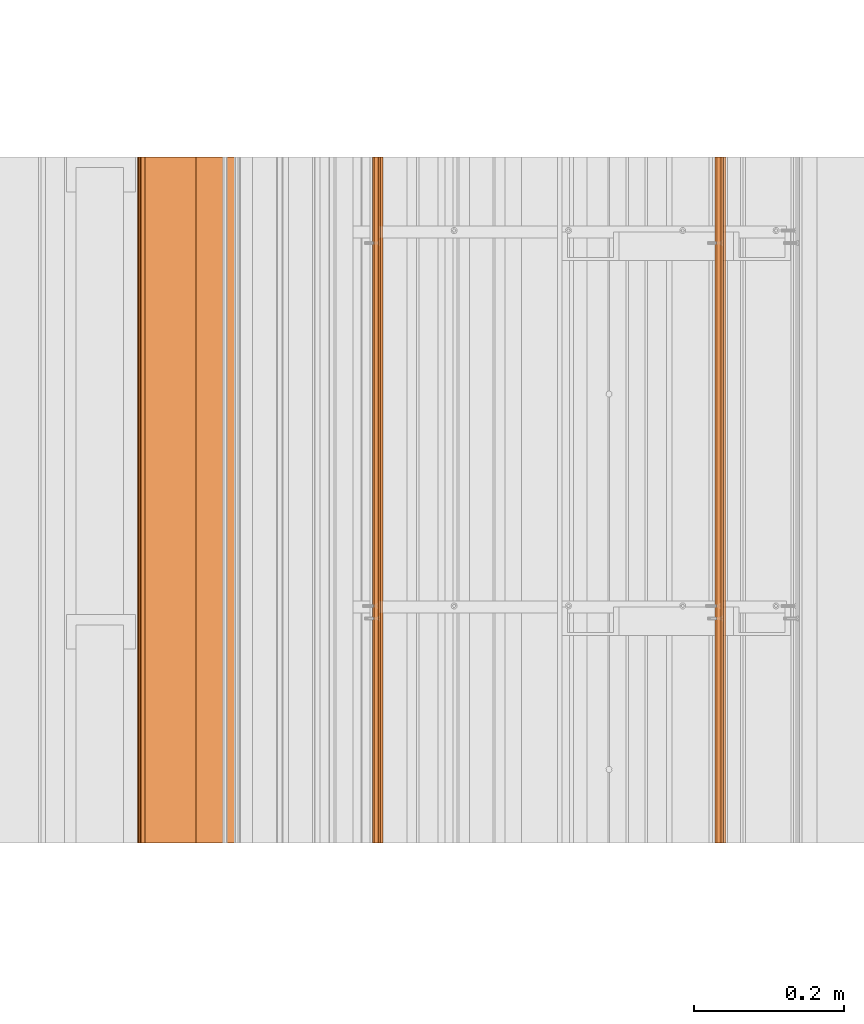
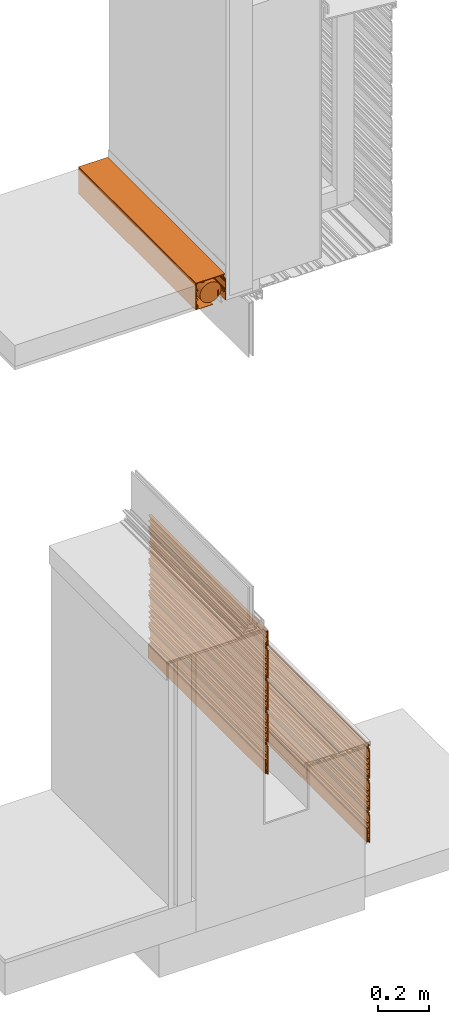
# One storey, part 4 of 36: 13 proxies.
"""IFC2X3 building model written with IfcOpenShell, lengths in feet."""

from ifc_helpers import new_model, entity, si_unit, converted_unit, derived_unit, direction, frame, frame_2d, origin, place, context, subcontext, project, spatial, polyline, circle_curve, parameter, trimmed, segment, composite_curve, outline, extrude, source, transform, mapped, material, type_object, type_shapes, element, save


model = new_model("IFC2X3")

# Units and contexts
model_context = context("Model", 3, precision=0.0001, world=origin(), true_north=direction((6.12303176911189e-17, 1.0)))
body_context = subcontext(model_context, "Body", "Model", "MODEL_VIEW")
ifc_project = project(units=[converted_unit("LENGTHUNIT", "FOOT", entity("IfcRatioMeasure", 0.3048), si_unit("LENGTHUNIT", "METRE"), dimensions=[1, 0, 0, 0, 0, 0, 0]), converted_unit("AREAUNIT", "SQUARE FOOT", entity("IfcRatioMeasure", 0.09290304), si_unit("AREAUNIT", "SQUARE_METRE"), dimensions=[2, 0, 0, 0, 0, 0, 0]), converted_unit("VOLUMEUNIT", "CUBIC FOOT", entity("IfcRatioMeasure", 0.028316846592), si_unit("VOLUMEUNIT", "CUBIC_METRE"), dimensions=[3, 0, 0, 0, 0, 0, 0]), converted_unit("PLANEANGLEUNIT", "DEGREE", entity("IfcRatioMeasure", 0.0174532925199433), si_unit("PLANEANGLEUNIT", "RADIAN"), dimensions=[0, 0, 0, 0, 0, 0, 0]), si_unit("MASSUNIT", "GRAM", prefix="KILO"), derived_unit("MASSDENSITYUNIT", [(si_unit("MASSUNIT", "GRAM", prefix="KILO"), 1), (si_unit("LENGTHUNIT", "METRE"), -3)]), si_unit("TIMEUNIT", "SECOND"), si_unit("FREQUENCYUNIT", "HERTZ"), si_unit("THERMODYNAMICTEMPERATUREUNIT", "DEGREE_CELSIUS"), derived_unit("THERMALTRANSMITTANCEUNIT", [(si_unit("MASSUNIT", "GRAM", prefix="KILO"), 1), (si_unit("THERMODYNAMICTEMPERATUREUNIT", "KELVIN"), -1), (si_unit("TIMEUNIT", "SECOND"), -3)]), derived_unit("VOLUMETRICFLOWRATEUNIT", [(si_unit("LENGTHUNIT", "METRE"), 3), (si_unit("TIMEUNIT", "SECOND"), -1)]), si_unit("ELECTRICCURRENTUNIT", "AMPERE"), si_unit("ELECTRICVOLTAGEUNIT", "VOLT"), si_unit("POWERUNIT", "WATT"), si_unit("FORCEUNIT", "NEWTON"), si_unit("ILLUMINANCEUNIT", "LUX"), si_unit("LUMINOUSFLUXUNIT", "LUMEN"), si_unit("LUMINOUSINTENSITYUNIT", "CANDELA"), derived_unit("USERDEFINED", [(si_unit("MASSUNIT", "GRAM", prefix="KILO"), -1), (si_unit("LENGTHUNIT", "METRE"), -2), (si_unit("TIMEUNIT", "SECOND"), 3), (si_unit("LUMINOUSFLUXUNIT", "LUMEN"), 1)]), derived_unit("LINEARVELOCITYUNIT", [(si_unit("LENGTHUNIT", "METRE"), 1), (si_unit("TIMEUNIT", "SECOND"), -1)]), si_unit("PRESSUREUNIT", "PASCAL"), derived_unit("USERDEFINED", [(si_unit("LENGTHUNIT", "METRE"), -2), (si_unit("MASSUNIT", "GRAM", prefix="KILO"), 1), (si_unit("TIMEUNIT", "SECOND"), -2)])], contexts=[model_context])

# Site, building, storey
site_placement = place(None, origin())
site = spatial("IfcSite", under=ifc_project, at=site_placement, CompositionType="ELEMENT")
building_placement = place(site_placement, origin())
building = spatial("IfcBuilding", under=site, at=building_placement, CompositionType="ELEMENT")
storey_placement = place(building_placement, origin())
storey = spatial("IfcBuildingStorey", under=building, at=storey_placement, Name="Level 1", CompositionType="ELEMENT", Elevation=0.0)

# Proxies
ifc_material_1 = material(Name="_EXISTING CAST-IN-PLACE CONCRETE")
building_element_proxy_type_1 = type_object("IfcBuildingElementProxyType", Name="panel 048", PredefinedType="NOTDEFINED", material=ifc_material_1)
shared_shape_1 = source(origin(), body_context, "Body", "SweptSolid", [
    extrude(outline(polyline([(-0.145680147068469, -0.0220175316851652), (0.291819852931525, -0.0220175316851652), (0.291819852931525, -0.011600865018508), (0.237132352931535, -0.011600865018508), (0.237132352931535, 0.00451787028335104), (0.257965686264864, 0.00451787028335104), (0.257965686264864, 0.0173047730392568), (0.226715686264859, 0.0173047730392568), (0.226715686264859, -0.011600865018508), (0.143382352931521, -0.011600865018508), (0.143382352931521, 0.0196491349815062), (0.132965686264868, 0.0196491349815062), (0.132965686264868, -0.011600865018508), (0.060049019598182, -0.011600865018508), (0.060049019598182, 0.0196491349815062), (0.049632352931531, 0.0196491349815062), (0.049632352931531, -0.011600865018508), (-0.023284313735132, -0.011600865018508), (-0.023284313735132, 0.0196491349815062), (-0.0337009804018078, 0.0196491349815062), (-0.0337009804018078, -0.011600865018508), (-0.135263480401817, -0.011600865018508), (-0.135263480401817, -0.00118419835182237), (-0.180710665113099, -0.00118419835182237), (-0.18994960080863, 0.018628763098306), (-0.215994026661651, 0.018628763098306), (-0.225232962029097, -0.00118419835182237), (-0.249846813735136, -0.00118419835182237), (-0.249846813735136, -0.011600865018508), (-0.218596813735132, -0.011600865018508), (-0.210299318000234, 0.00619317215341653), (-0.195644309470049, 0.00619317215341653), (-0.187346813735151, -0.011600865018508), (-0.145680147068469, -0.011600865018508), (-0.145680147068469, -0.0220175316851652)])), frame((123.592814019473, -64.2284331589239, 2.88253665109421), z_axis=(0.0, 1.0, 0.0), x_axis=(0.0, 0.0, -1.0)), (0.0, 0.0, 1.0), 3.0),
])
type_shapes(building_element_proxy_type_1, [shared_shape_1])
proxy_1_placement = place(storey_placement, origin())
element("IfcBuildingElementProxy", 1, at=proxy_1_placement, inside=storey, type_object=building_element_proxy_type_1, material=ifc_material_1, Name="panel 048:panel 048", ObjectType="panel 048", context=body_context, shape_type="MappedRepresentation", body=[
    mapped(shared_shape_1, transform((0.0, 0.0, 0.0), scale=1.0)),
])
building_element_proxy_type_2 = type_object("IfcBuildingElementProxyType", Name="panel 049", PredefinedType="NOTDEFINED", material=ifc_material_1)
shared_shape_2 = source(origin(), body_context, "Body", "SweptSolid", [
    extrude(outline(polyline([(-0.145680147068469, -0.0220175316851652), (0.291819852931525, -0.0220175316851652), (0.291819852931525, -0.011600865018508), (0.237132352931535, -0.011600865018508), (0.237132352931535, 0.00451787028335104), (0.257965686264864, 0.00451787028335104), (0.257965686264864, 0.0173047730392568), (0.22671568626486, 0.0173047730392568), (0.22671568626486, -0.011600865018508), (0.143382352931521, -0.011600865018508), (0.143382352931521, 0.0196491349815062), (0.132965686264868, 0.0196491349815062), (0.132965686264868, -0.011600865018508), (0.060049019598182, -0.011600865018508), (0.060049019598182, 0.0196491349815062), (0.049632352931531, 0.0196491349815062), (0.049632352931531, -0.011600865018508), (-0.023284313735132, -0.011600865018508), (-0.023284313735132, 0.0196491349815062), (-0.0337009804018078, 0.0196491349815062), (-0.0337009804018078, -0.011600865018508), (-0.135263480401816, -0.011600865018508), (-0.135263480401816, -0.00118419835182237), (-0.180710665113098, -0.00118419835182237), (-0.18994960080863, 0.018628763098306), (-0.215994026661651, 0.018628763098306), (-0.225232962029097, -0.00118419835182237), (-0.249846813735136, -0.00118419835182237), (-0.249846813735136, -0.011600865018508), (-0.218596813735132, -0.011600865018508), (-0.210299318000233, 0.00619317215341653), (-0.195644309470049, 0.00619317215341653), (-0.187346813735151, -0.011600865018508), (-0.145680147068469, -0.011600865018508), (-0.145680147068469, -0.0220175316851652)])), frame((123.592814019473, -64.2284331589239, 2.38253665109421), z_axis=(0.0, 1.0, 0.0), x_axis=(0.0, 0.0, -1.0)), (0.0, 0.0, 1.0), 3.0),
])
type_shapes(building_element_proxy_type_2, [shared_shape_2])
proxy_2_placement = place(storey_placement, origin())
element("IfcBuildingElementProxy", 2, at=proxy_2_placement, inside=storey, type_object=building_element_proxy_type_2, material=ifc_material_1, Name="panel 049:panel 049", ObjectType="panel 049", context=body_context, shape_type="MappedRepresentation", body=[
    mapped(shared_shape_2, transform((0.0, 0.0, 0.0), scale=1.0)),
])
building_element_proxy_type_3 = type_object("IfcBuildingElementProxyType", Name="starter strip 014", PredefinedType="NOTDEFINED", material=ifc_material_1)
shared_shape_3 = source(origin(), body_context, "Body", "SweptSolid", [
    extrude(outline(polyline([(-0.050489778625332, 0.00592609117455822), (-0.0251609571030125, 0.00592609117455822), (-0.0251609571030125, 0.0154211444225751), (-0.0613594856463293, 0.0154211444225751), (-0.0613594856463293, -0.0159630966207374), (0.137010221374674, -0.0159630966207374), (0.137010221374674, -0.00538413897638179), (-0.050489778625332, -0.00538413897638179), (-0.050489778625332, 0.00592609117455822)])), frame((123.583785406736, -64.2284331589239, 2.17160753380901), z_axis=(0.0, 1.0, 0.0), x_axis=(0.0, 0.0, 1.0)), (0.0, 0.0, 1.0), 3.0),
])
type_shapes(building_element_proxy_type_3, [shared_shape_3])
proxy_3_placement = place(storey_placement, origin())
element("IfcBuildingElementProxy", 3, at=proxy_3_placement, inside=storey, type_object=building_element_proxy_type_3, material=ifc_material_1, Name="starter strip 014:starter strip 014", ObjectType="starter strip 014", context=body_context, shape_type="MappedRepresentation", body=[
    mapped(shared_shape_3, transform((0.0, 0.0, 0.0), scale=1.0)),
])
building_element_proxy_type_4 = type_object("IfcBuildingElementProxyType", Name="panel 050", PredefinedType="NOTDEFINED", material=ifc_material_1)
shared_shape_4 = source(origin(), body_context, "Body", "SweptSolid", [
    extrude(outline(polyline([(-0.145680147068469, -0.0220175316851652), (0.291819852931525, -0.0220175316851652), (0.291819852931525, -0.011600865018508), (0.237132352931535, -0.011600865018508), (0.237132352931535, 0.00451787028335104), (0.257965686264864, 0.00451787028335104), (0.257965686264864, 0.0173047730392568), (0.226715686264859, 0.0173047730392568), (0.226715686264859, -0.011600865018508), (0.14338235293152, -0.011600865018508), (0.14338235293152, 0.0196491349815062), (0.132965686264868, 0.0196491349815062), (0.132965686264868, -0.011600865018508), (0.0600490195981815, -0.011600865018508), (0.0600490195981815, 0.0196491349815062), (0.0496323529315306, 0.0196491349815062), (0.0496323529315306, -0.011600865018508), (-0.0232843137351324, -0.011600865018508), (-0.0232843137351324, 0.0196491349815062), (-0.0337009804018082, 0.0196491349815062), (-0.0337009804018082, -0.011600865018508), (-0.135263480401817, -0.011600865018508), (-0.135263480401817, -0.00118419835182237), (-0.180710665113099, -0.00118419835182237), (-0.18994960080863, 0.018628763098306), (-0.215994026661652, 0.018628763098306), (-0.225232962029098, -0.00118419835182237), (-0.249846813735137, -0.00118419835182237), (-0.249846813735137, -0.011600865018508), (-0.218596813735132, -0.011600865018508), (-0.210299318000234, 0.00619317215341653), (-0.19564430947005, 0.00619317215341653), (-0.187346813735152, -0.011600865018508), (-0.145680147068469, -0.011600865018508), (-0.145680147068469, -0.0220175316851652)])), frame((123.592814019473, -64.2284331589239, 3.38253665109421), z_axis=(0.0, 1.0, 0.0), x_axis=(0.0, 0.0, -1.0)), (0.0, 0.0, 1.0), 3.0),
])
type_shapes(building_element_proxy_type_4, [shared_shape_4])
proxy_4_placement = place(storey_placement, origin())
element("IfcBuildingElementProxy", 4, at=proxy_4_placement, inside=storey, type_object=building_element_proxy_type_4, material=ifc_material_1, Name="panel 050:panel 050", ObjectType="panel 050", context=body_context, shape_type="MappedRepresentation", body=[
    mapped(shared_shape_4, transform((0.0, 0.0, 0.0), scale=1.0)),
])
building_element_proxy_type_5 = type_object("IfcBuildingElementProxyType", Name="panel 051", PredefinedType="NOTDEFINED", material=ifc_material_1)
shared_shape_5 = source(origin(), body_context, "Body", "SweptSolid", [
    extrude(outline(polyline([(-0.14568014706847, -0.0220175316851652), (0.291819852931525, -0.0220175316851652), (0.291819852931525, -0.011600865018508), (0.237132352931535, -0.011600865018508), (0.237132352931535, 0.00451787028335104), (0.257965686264864, 0.00451787028335104), (0.257965686264864, 0.0173047730392568), (0.226715686264859, 0.0173047730392568), (0.226715686264859, -0.011600865018508), (0.14338235293152, -0.011600865018508), (0.14338235293152, 0.0196491349815062), (0.132965686264868, 0.0196491349815062), (0.132965686264868, -0.011600865018508), (0.0600490195981815, -0.011600865018508), (0.0600490195981815, 0.0196491349815062), (0.0496323529315306, 0.0196491349815062), (0.0496323529315306, -0.011600865018508), (-0.0232843137351324, -0.011600865018508), (-0.0232843137351324, 0.0196491349815062), (-0.0337009804018082, 0.0196491349815062), (-0.0337009804018082, -0.011600865018508), (-0.135263480401817, -0.011600865018508), (-0.135263480401817, -0.00118419835182237), (-0.180710665113099, -0.00118419835182237), (-0.189949600808631, 0.018628763098306), (-0.215994026661652, 0.018628763098306), (-0.225232962029097, -0.00118419835182237), (-0.249846813735137, -0.00118419835182237), (-0.249846813735137, -0.011600865018508), (-0.218596813735132, -0.011600865018508), (-0.210299318000234, 0.00619317215341653), (-0.195644309470049, 0.00619317215341653), (-0.187346813735151, -0.011600865018508), (-0.14568014706847, -0.011600865018508), (-0.14568014706847, -0.0220175316851652)])), frame((123.592814019473, -64.2284331589239, 3.88253665109421), z_axis=(0.0, 1.0, 0.0), x_axis=(0.0, 0.0, -1.0)), (0.0, 0.0, 1.0), 3.0),
])
type_shapes(building_element_proxy_type_5, [shared_shape_5])
proxy_5_placement = place(storey_placement, origin())
element("IfcBuildingElementProxy", 5, at=proxy_5_placement, inside=storey, type_object=building_element_proxy_type_5, material=ifc_material_1, Name="panel 051:panel 051", ObjectType="panel 051", context=body_context, shape_type="MappedRepresentation", body=[
    mapped(shared_shape_5, transform((0.0, 0.0, 0.0), scale=1.0)),
])
building_element_proxy_type_6 = type_object("IfcBuildingElementProxyType", Name="panel 052", PredefinedType="NOTDEFINED", material=ifc_material_1)
shared_shape_6 = source(origin(), body_context, "Body", "SweptSolid", [
    extrude(outline(polyline([(-0.14568014706847, -0.0220175316851794), (0.291819852931525, -0.0220175316851794), (0.291819852931525, -0.011600865018508), (0.237132352931535, -0.011600865018508), (0.237132352931535, 0.00451787028333683), (0.257965686264863, 0.00451787028333683), (0.257965686264863, 0.0173047730392426), (0.226715686264859, 0.0173047730392426), (0.226715686264859, -0.011600865018508), (0.14338235293152, -0.011600865018508), (0.14338235293152, 0.0196491349815062), (0.132965686264868, 0.0196491349815062), (0.132965686264868, -0.011600865018508), (0.0600490195981815, -0.011600865018508), (0.0600490195981815, 0.0196491349815062), (0.0496323529315303, 0.0196491349815062), (0.0496323529315303, -0.011600865018508), (-0.0232843137351324, -0.011600865018508), (-0.0232843137351324, 0.0196491349815062), (-0.0337009804018082, 0.0196491349815062), (-0.0337009804018082, -0.011600865018508), (-0.135263480401817, -0.011600865018508), (-0.135263480401817, -0.00118419835182237), (-0.180710665113099, -0.00118419835182237), (-0.189949600808631, 0.018628763098306), (-0.215994026661652, 0.018628763098306), (-0.225232962029098, -0.00118419835182237), (-0.249846813735137, -0.00118419835182237), (-0.249846813735137, -0.011600865018508), (-0.218596813735132, -0.011600865018508), (-0.210299318000234, 0.00619317215341653), (-0.19564430947005, 0.00619317215341653), (-0.187346813735152, -0.011600865018508), (-0.14568014706847, -0.011600865018508), (-0.14568014706847, -0.0220175316851794)])), frame((125.092613051196, -64.2284331589239, 1.79181985293804), z_axis=(0.0, 1.0, 0.0), x_axis=(0.0, 0.0, -1.0)), (0.0, 0.0, 1.0), 3.0),
])
type_shapes(building_element_proxy_type_6, [shared_shape_6])
proxy_6_placement = place(storey_placement, origin())
element("IfcBuildingElementProxy", 6, at=proxy_6_placement, inside=storey, type_object=building_element_proxy_type_6, material=ifc_material_1, Name="panel 052:panel 052", ObjectType="panel 052", context=body_context, shape_type="MappedRepresentation", body=[
    mapped(shared_shape_6, transform((0.0, 0.0, 0.0), scale=1.0)),
])
building_element_proxy_type_7 = type_object("IfcBuildingElementProxyType", Name="starter strip 015", PredefinedType="NOTDEFINED", material=ifc_material_1)
shared_shape_7 = source(origin(), body_context, "Body", "SweptSolid", [
    extrude(outline(polyline([(-0.0504897786253321, 0.00592609117454401), (-0.0251609571030125, 0.00592609117454401), (-0.0251609571030125, 0.0154211444225609), (-0.0613594856463293, 0.0154211444225609), (-0.0613594856463293, -0.0159630966207374), (0.137010221374674, -0.0159630966207374), (0.137010221374674, -0.00538413897638179), (-0.0504897786253321, -0.00538413897638179), (-0.0504897786253321, 0.00592609117454401)])), frame((125.083584438458, -64.2284331589239, 0.580890735652844), z_axis=(0.0, 1.0, 0.0), x_axis=(0.0, 0.0, 1.0)), (0.0, 0.0, 1.0), 3.0),
])
type_shapes(building_element_proxy_type_7, [shared_shape_7])
proxy_7_placement = place(storey_placement, origin())
element("IfcBuildingElementProxy", 7, at=proxy_7_placement, inside=storey, type_object=building_element_proxy_type_7, material=ifc_material_1, Name="starter strip 015:starter strip 015", ObjectType="starter strip 015", context=body_context, shape_type="MappedRepresentation", body=[
    mapped(shared_shape_7, transform((0.0, 0.0, 0.0), scale=1.0)),
])
building_element_proxy_type_8 = type_object("IfcBuildingElementProxyType", Name="panel 053", PredefinedType="NOTDEFINED", material=ifc_material_1)
shared_shape_8 = source(origin(), body_context, "Body", "SweptSolid", [
    extrude(outline(polyline([(-0.145680147068469, -0.0220175316851794), (0.291819852931525, -0.0220175316851794), (0.291819852931525, -0.011600865018508), (0.237132352931535, -0.011600865018508), (0.237132352931535, 0.00451787028333683), (0.257965686264864, 0.00451787028333683), (0.257965686264864, 0.0173047730392426), (0.226715686264859, 0.0173047730392426), (0.226715686264859, -0.011600865018508), (0.143382352931521, -0.011600865018508), (0.143382352931521, 0.0196491349815062), (0.132965686264868, 0.0196491349815062), (0.132965686264868, -0.011600865018508), (0.0600490195981819, -0.011600865018508), (0.0600490195981819, 0.0196491349815062), (0.0496323529315307, 0.0196491349815062), (0.0496323529315307, -0.011600865018508), (-0.0232843137351321, -0.011600865018508), (-0.0232843137351321, 0.0196491349815062), (-0.033700980401808, 0.0196491349815062), (-0.033700980401808, -0.011600865018508), (-0.135263480401817, -0.011600865018508), (-0.135263480401817, -0.00118419835182237), (-0.180710665113099, -0.00118419835182237), (-0.18994960080863, 0.018628763098306), (-0.215994026661652, 0.018628763098306), (-0.225232962029098, -0.00118419835182237), (-0.249846813735137, -0.00118419835182237), (-0.249846813735137, -0.011600865018508), (-0.218596813735132, -0.011600865018508), (-0.210299318000234, 0.00619317215341653), (-0.19564430947005, 0.00619317215341653), (-0.187346813735151, -0.011600865018508), (-0.145680147068469, -0.011600865018508), (-0.145680147068469, -0.0220175316851794)])), frame((125.092613051196, -64.2284331589239, 0.791819852938045), z_axis=(0.0, 1.0, 0.0), x_axis=(0.0, 0.0, -1.0)), (0.0, 0.0, 1.0), 3.0),
])
type_shapes(building_element_proxy_type_8, [shared_shape_8])
proxy_8_placement = place(storey_placement, origin())
element("IfcBuildingElementProxy", 8, at=proxy_8_placement, inside=storey, type_object=building_element_proxy_type_8, material=ifc_material_1, Name="panel 053:panel 053", ObjectType="panel 053", context=body_context, shape_type="MappedRepresentation", body=[
    mapped(shared_shape_8, transform((0.0, 0.0, 0.0), scale=1.0)),
])
building_element_proxy_type_9 = type_object("IfcBuildingElementProxyType", Name="panel 054", PredefinedType="NOTDEFINED", material=ifc_material_1)
shared_shape_9 = source(origin(), body_context, "Body", "SweptSolid", [
    extrude(outline(polyline([(-0.145680147068469, -0.0220175316851794), (0.291819852931525, -0.0220175316851794), (0.291819852931525, -0.011600865018508), (0.237132352931535, -0.011600865018508), (0.237132352931535, 0.00451787028333683), (0.257965686264864, 0.00451787028333683), (0.257965686264864, 0.0173047730392426), (0.226715686264859, 0.0173047730392426), (0.226715686264859, -0.011600865018508), (0.143382352931521, -0.011600865018508), (0.143382352931521, 0.0196491349815062), (0.132965686264868, 0.0196491349815062), (0.132965686264868, -0.011600865018508), (0.060049019598182, -0.011600865018508), (0.060049019598182, 0.0196491349815062), (0.049632352931531, 0.0196491349815062), (0.049632352931531, -0.011600865018508), (-0.023284313735132, -0.011600865018508), (-0.023284313735132, 0.0196491349815062), (-0.0337009804018078, 0.0196491349815062), (-0.0337009804018078, -0.011600865018508), (-0.135263480401817, -0.011600865018508), (-0.135263480401817, -0.00118419835182237), (-0.180710665113099, -0.00118419835182237), (-0.18994960080863, 0.018628763098306), (-0.215994026661651, 0.018628763098306), (-0.225232962029097, -0.00118419835182237), (-0.249846813735136, -0.00118419835182237), (-0.249846813735136, -0.011600865018508), (-0.218596813735132, -0.011600865018508), (-0.210299318000234, 0.00619317215341653), (-0.195644309470049, 0.00619317215341653), (-0.187346813735151, -0.011600865018508), (-0.145680147068469, -0.011600865018508), (-0.145680147068469, -0.0220175316851794)])), frame((125.092613051196, -64.2284331589239, 1.29181985293804), z_axis=(0.0, 1.0, 0.0), x_axis=(0.0, 0.0, -1.0)), (0.0, 0.0, 1.0), 3.0),
])
type_shapes(building_element_proxy_type_9, [shared_shape_9])
proxy_9_placement = place(storey_placement, origin())
element("IfcBuildingElementProxy", 9, at=proxy_9_placement, inside=storey, type_object=building_element_proxy_type_9, material=ifc_material_1, Name="panel 054:panel 054", ObjectType="panel 054", context=body_context, shape_type="MappedRepresentation", body=[
    mapped(shared_shape_9, transform((0.0, 0.0, 0.0), scale=1.0)),
])
ifc_material_2 = material()
building_element_proxy_type_10 = type_object("IfcBuildingElementProxyType", Name="003", PredefinedType="NOTDEFINED", material=ifc_material_2)
shared_shape_10 = source(origin(), body_context, "Body", "SweptSolid", [
    extrude(outline(polyline([(-0.0198255639184026, -0.117953431372548), (0.0114244360815832, -0.117953431372548), (0.0218411027479277, -0.117953431372581), (0.0218411027482688, 0.124234068627452), (0.0114244360815832, 0.124234068627452), (0.0114244360815832, 0.0695465686274517), (-0.00469429922024744, 0.0695465686274517), (-0.00469429922024744, 0.0903799019607856), (-0.0174812019761532, 0.0903799019607856), (-0.0174812019761532, 0.0591299019607856), (0.0114244360815832, 0.0591299019607856), (0.0114244360815832, -0.0242034313725483), (-0.0198255639184026, -0.0242034313725483), (-0.0198255639184026, -0.0346200980392144), (0.0114244360815832, -0.0346200980392144), (0.0114244360815832, -0.107536764705881), (-0.0198255639184026, -0.107536764705881), (-0.0198255639184026, -0.117953431372548)])), frame((123.59299044841, -64.2284331589239, 4.21495086679015), z_axis=(0.0, 1.0, 0.0), x_axis=(1.0, 0.0, 0.0)), (0.0, 0.0, 1.0), 3.00000000000001),
])
type_shapes(building_element_proxy_type_10, [shared_shape_10])
proxy_10_placement = place(storey_placement, origin())
element("IfcBuildingElementProxy", 10, at=proxy_10_placement, inside=storey, type_object=building_element_proxy_type_10, material=ifc_material_2, Name="003:003", ObjectType="003", context=body_context, shape_type="MappedRepresentation", body=[
    mapped(shared_shape_10, transform((0.0, 0.0, 0.0), scale=1.0)),
])
building_element_proxy_type_11 = type_object("IfcBuildingElementProxyType", Name="Shade pocket part 015", PredefinedType="NOTDEFINED", material=ifc_material_1)
shared_shape_11 = source(origin(), body_context, "Body", "SweptSolid", [
    extrude(outline(polyline([(0.107793603576924, -0.220594726386571), (0.107244718650941, -0.227810244951675), (0.124993195008335, -0.228238803210528), (0.171387783779594, 0.201652966945797), (0.16901674833012, 0.204576476477441), (-0.245264221774335, 0.247805781268262), (-0.246130701646431, 0.239502013171024), (-0.223665218924281, 0.236026249124568), (-0.223244932819473, 0.230275794923725), (-0.218702890465289, 0.229801842829686), (-0.216806454447826, 0.234705618780179), (-0.210443832660143, 0.234916264408031), (-0.207790703259201, 0.229610632418617), (-0.210332867700847, 0.225503045830652), (-0.216509293493594, 0.224981447618561), (-0.216892969076541, 0.221304555439105), (-0.209150494107328, 0.218674622699116), (-0.209481508327277, 0.215502402076499), (-0.185105732223287, 0.212958843644533), (-0.184299469210997, 0.220685533317359), (-0.202593806931382, 0.222594507077514), (-0.201361907566572, 0.234400213100172), (-0.116117201285392, 0.225505116159793), (-0.100541034084104, 0.198929892178394), (-0.0939404560314465, 0.19824113642801), (-0.078359743969423, 0.2063459773775), (-0.0772979122128076, 0.216521868300265), (-0.0838984902654683, 0.217210624050649), (-0.083410621562096, 0.2218860339536), (0.0392501230005629, 0.209086656006716), (0.0387239043562807, 0.204043725719145), (0.0330970428514953, 0.204630876297036), (0.0325798332030988, 0.199674282247654), (0.0381672671129975, 0.199091245852261), (0.0367002724456017, 0.185032542459098), (0.0485059784682421, 0.183800643094291), (0.0489855728820628, 0.188396757697006), (0.0420463410471482, 0.18912085122206), (0.0440771695934021, 0.208582964349461), (0.0766703841871469, 0.205181934349385), (0.0753378988981246, 0.192412279577994), (0.083358569901888, 0.191575340262724), (0.0846910551909103, 0.204344995034115), (0.146056013852455, 0.197941697048241), (0.146262780788235, 0.191294444084172), (0.149435000582006, 0.190963429950711), (0.151324791317172, 0.195663833162877), (0.157014726095524, 0.197110766805703), (0.16082088941891, 0.193914973993944), (0.160285248284815, 0.188781744816782), (0.157036794624047, 0.18614717198495), (0.153844011150704, 0.185722370438157), (0.153506978565871, 0.182492473800282), (0.159834366999727, 0.18054952046086), (0.15297291375465, 0.114793905827418), (0.135233840397937, 0.116644938976854), (0.134425112508601, 0.108894627558107), (0.152264933524706, 0.106122070329353), (0.150769727431378, 0.0917930073511865), (0.132835868328831, 0.0936643659632516), (0.132102370995134, 0.0866350142666773), (0.150036230097681, 0.0847636556546122), (0.135883816706146, -0.0508636827338842), (0.125425266313819, -0.0497723560855323), (0.123885392151054, -0.064529488199411), (0.129405235543078, -0.0651054716734558), (0.130016483277916, -0.0592476790073847), (0.134747778087556, -0.0597413791774156), (0.122101992683646, -0.180930194732387), (0.116687318277533, -0.180365185409884), (0.11715750888271, -0.175859190668832), (0.112426214073071, -0.175365490498801), (0.110839320867086, -0.19057322192101), (0.11380340342017, -0.191502005652045), (0.117264007019914, -0.191863111999112), (0.119298052521173, -0.194371109680907), (0.120248778675628, -0.198879611390018), (0.116466877830802, -0.201946822518437), (0.111960883089749, -0.20147663191326), (0.109870101418335, -0.197067810719193), (0.106625785569462, -0.19672927352152), (0.104011525159202, -0.200829336216462), (0.0763500503939543, -0.197942922381694), (0.0387118919062505, -0.223607941816078), (0.0206879133564578, -0.221727179438612), (0.0178124027611734, -0.218181647196351), (0.0346594354790452, -0.206786867547206), (0.0350590974761472, -0.20295677218309), (0.0323853770134382, -0.199660049116634), (0.0284989566321623, -0.199254509728318), (-0.000276716625925898, -0.219653442252323), (-0.112425467942929, -0.207950967597573), (-0.115163912371213, -0.204574439258557), (-0.114750832253732, -0.20061575353301), (-0.119504297970187, -0.200254725699317), (-0.119951150946495, -0.204537068092163), (-0.123261605348785, -0.205284843860421), (-0.128755001085753, -0.203800608019486), (-0.129067677624072, -0.198939619644476), (-0.125136491502634, -0.195751334622131), (-0.121021342830385, -0.192764447314151), (-0.122887902020527, -0.190462961866106), (-0.127405162262309, -0.189991595730794), (-0.129337303291926, -0.187609247243418), (-0.128764258470245, -0.182117565945561), (-0.147224878196326, -0.175636182932292), (-0.149856379037749, -0.181647571997198), (-0.136205957814023, -0.187900324799294), (-0.141899182999994, -0.201426929238035), (-0.153916475632445, -0.196984410947683), (-0.156747023728006, -0.203157231289803), (-0.289876471889578, -0.189265467229872), (-0.290636493808439, -0.196549012948916), (0.0515217932712669, -0.232252474962015), (0.0523538559354033, -0.224278538546564), (0.0618586886959182, -0.225270346865171), (0.062630095146729, -0.217877699346709), (0.0785434192633704, -0.206905050820621), (0.119255432908833, -0.211153259581173), (0.118270236687776, -0.220594726386571), (0.107793603576924, -0.220594726386571)])), frame((122.76209859202, -64.2284325288056, 9.97840418331688), z_axis=(0.0, -1.0, 0.0), x_axis=(-0.103784296777212, 0.0, 0.994599828947532)), (0.0, 0.0, -1.0), 2.99999999999999),
])
type_shapes(building_element_proxy_type_11, [shared_shape_11])
proxy_11_placement = place(storey_placement, origin())
element("IfcBuildingElementProxy", 11, at=proxy_11_placement, inside=storey, type_object=building_element_proxy_type_11, material=ifc_material_1, Name="Shade pocket part 015:Shade pocket part 015", ObjectType="Shade pocket part 015", context=body_context, shape_type="MappedRepresentation", body=[
    mapped(shared_shape_11, transform((0.0, 0.0, 0.0), scale=1.0)),
])
building_element_proxy_type_12 = type_object("IfcBuildingElementProxyType", Name="Shade pocket part 016", PredefinedType="NOTDEFINED", material=ifc_material_1)
shared_shape_12 = source(origin(), body_context, "Body", "SweptSolid", [
    extrude(outline(polyline([(-0.045054157291645, -0.0362869659722254), (-0.0274986256249861, -0.0362869659722254), (-0.0274986256249861, 0.0277986906944427), (0.194960673541686, 0.0277986906944427), (0.194960673541686, 0.0329389931944419), (-0.0500382389583365, 0.0329389931944419), (-0.0500382389583365, 0.0277742690277751), (-0.0322134572916468, 0.0277742690277751), (-0.0322134572916468, -0.0307344543055592), (-0.0399820989583191, -0.0307344543055592), (-0.0399820989583191, -0.0215376209722251), (-0.0454023481249806, -0.0214434443055573), (-0.045054157291645, -0.0362869659722254)])), frame((122.601714288099, -64.2284325700292, 9.7414618155747), z_axis=(0.0, 1.0, 0.0), x_axis=(1.0, 0.0, 0.0)), (0.0, 0.0, 1.0), 2.99999999999999),
])
type_shapes(building_element_proxy_type_12, [shared_shape_12])
proxy_12_placement = place(storey_placement, origin())
element("IfcBuildingElementProxy", 12, at=proxy_12_placement, inside=storey, type_object=building_element_proxy_type_12, material=ifc_material_1, Name="Shade pocket part 016:Shade pocket part 016", ObjectType="Shade pocket part 016", context=body_context, shape_type="MappedRepresentation", body=[
    mapped(shared_shape_12, transform((0.0, 0.0, 0.0), scale=1.0)),
])
building_element_proxy_type_13 = type_object("IfcBuildingElementProxyType", Name="Shade roll003", PredefinedType="NOTDEFINED", material=ifc_material_1)
shared_shape_13 = source(origin(), body_context, "Body", "SweptSolid", [
    extrude(outline(composite_curve([segment(polyline([(-0.00515053666671861, -0.0551881001271756), (-0.00515053666671861, 0.0501316128383763)]), True, "CONTINUOUS"), segment(trimmed(circle_curve(frame_2d((0.108982059166621, -0.0558209976275461), x_axis=(1.0, 0.0)), 0.155731195), [parameter(137.128552899036)], [parameter(131.815609484802)], True, "PARAMETER"), True, "CONTINUOUS"), segment(polyline([(0.00515053666661913, 0.0602445874161632), (0.00515053666661913, -0.0551881001271756)]), True, "CONTINUOUS"), segment(polyline([(0.00515053666661913, -0.0551881001271756), (-0.00515053666671861, -0.0551881001271756)]), True, "CONTINUOUS")], self_intersect=False)), frame((122.86917428914, -64.2284325587704, 9.85735096988063), z_axis=(0.0, -1.0, 1.19209219847743e-07), x_axis=(-1.0, 0.0, 0.0)), (0.0, 0.0, -1.0), 3.00000000000001),
])
type_shapes(building_element_proxy_type_13, [shared_shape_13])
proxy_13_placement = place(storey_placement, origin())
element("IfcBuildingElementProxy", 13, at=proxy_13_placement, inside=storey, type_object=building_element_proxy_type_13, material=ifc_material_1, Name="Shade roll003:Shade roll003", ObjectType="Shade roll003", context=body_context, shape_type="MappedRepresentation", body=[
    mapped(shared_shape_13, transform((0.0, 0.0, 0.0), scale=1.0)),
])

save(model, "model.ifc")
